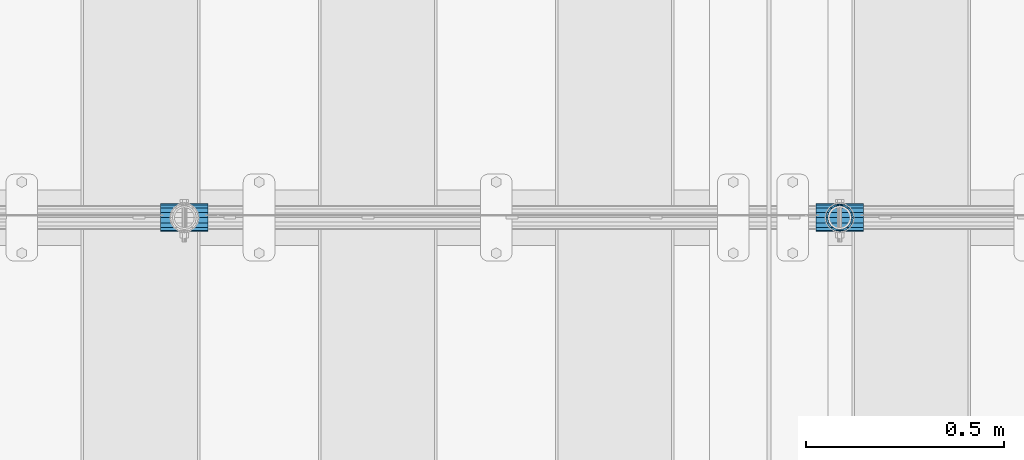
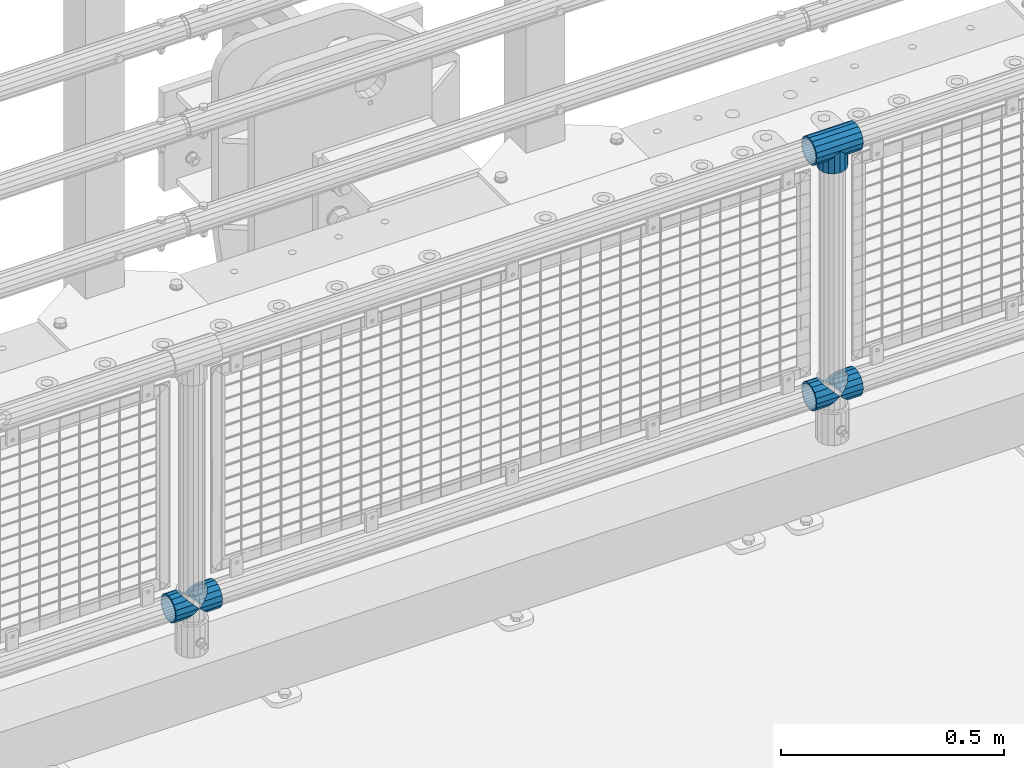
# One storey, part 142 of 219: 6 beams.
"""IFC2X3 building model written with IfcOpenShell, lengths in millimetres."""

import ifcopenshell
import ifcopenshell.guid

model = None  # the IFC model being written
_history = None  # IfcOwnerHistory: only IFC2X3 demands one
_inside = {}  # id of a spatial element -> (the spatial element, [elements in it])
_under = {}  # id of a project, library or spatial element -> (it, [spatial elements below it])
_declared = {}  # id of a project -> (the project, [libraries it declares])
_typed = {}  # id of a type object -> (the type object, [elements of that type])
_made_of = {}  # id of a material, layer set ... -> (it, [elements and type objects made of it])


def new_model(schema):
    """Start an empty IFC model of exactly this schema.

    Asked for "IFC4X3", IfcOpenShell would pick the latest addendum, in which some entities
    have other attributes; the version numbers below select the first issue.
    IFC2X3 requires an IfcOwnerHistory on every rooted entity: one is made here for all.
    """
    global model, _history
    if schema == "IFC4X3":
        model = ifcopenshell.file(schema_version=(4, 3, 0, 0))
    else:
        model = ifcopenshell.file(schema=schema)
    _inside.clear()
    _under.clear()
    _declared.clear()
    _typed.clear()
    _made_of.clear()
    _history = None
    if model.schema == "IFC2X3":
        org = make("IfcOrganization", Name="unknown")
        user = make(
            "IfcPersonAndOrganization",
            ThePerson=make("IfcPerson", FamilyName="unknown"),
            TheOrganization=org,
        )
        app = make(
            "IfcApplication",
            ApplicationDeveloper=org,
            Version="unknown",
            ApplicationFullName="unknown",
            ApplicationIdentifier="unknown",
        )
        _history = make(
            "IfcOwnerHistory",
            OwningUser=user,
            OwningApplication=app,
            ChangeAction="ADDED",
            CreationDate=0,
        )
    return model


def make(cls, **values):
    """One entity of the class cls with the attributes given. An attribute that is None is left unset."""
    return model.create_entity(
        cls, **{name: value for name, value in values.items() if value is not None}
    )


def rooted(cls, **values):
    """An entity with a GlobalId (a new one), such as an element, a storey or a relation."""
    return make(cls, GlobalId=ifcopenshell.guid.new(), OwnerHistory=_history, **values)


def si_unit(unit_type, name, prefix=None):
    """IfcSIUnit, for example si_unit("LENGTHUNIT", "METRE", prefix="MILLI")."""
    return make("IfcSIUnit", UnitType=unit_type, Prefix=prefix, Name=name)


def assignment(units):
    """IfcUnitAssignment: the units of a project."""
    return None if units is None else make("IfcUnitAssignment", Units=units)


def point(xyz):
    """IfcCartesianPoint."""
    return None if xyz is None else make("IfcCartesianPoint", Coordinates=xyz)


def direction(xyz):
    """IfcDirection."""
    return None if xyz is None else make("IfcDirection", DirectionRatios=xyz)


def frame(location, z_axis=None, x_axis=None):
    """IfcAxis2Placement3D, a coordinate frame: its origin and axes. An axis left out is left unset."""
    return make(
        "IfcAxis2Placement3D",
        Location=point(location),
        Axis=direction(z_axis),
        RefDirection=direction(x_axis),
    )


def origin_with_axes():
    """The frame at (0, 0, 0) with the z axis (0, 0, 1) and the x axis (1, 0, 0) written out."""
    return frame((0.0, 0.0, 0.0), z_axis=(0.0, 0.0, 1.0), x_axis=(1.0, 0.0, 0.0))


def place(relative_to, where):
    """IfcLocalPlacement: puts the frame where relative to a parent placement (None: the world)."""
    return make(
        "IfcLocalPlacement", PlacementRelTo=relative_to, RelativePlacement=where
    )


def context(
    kind, dimensions, precision=None, world=None, true_north=None, identifier=None
):
    """IfcGeometricRepresentationContext, for example the 3D "Model" context."""
    return make(
        "IfcGeometricRepresentationContext",
        ContextIdentifier=identifier,
        ContextType=kind,
        CoordinateSpaceDimension=dimensions,
        Precision=precision,
        WorldCoordinateSystem=world,
        TrueNorth=true_north,
    )


def subcontext(parent, identifier, kind, view, scale=None):
    """IfcGeometricRepresentationSubContext, for example "Body" below "Model"."""
    return make(
        "IfcGeometricRepresentationSubContext",
        ContextIdentifier=identifier,
        ContextType=kind,
        ParentContext=parent,
        TargetScale=scale,
        TargetView=view,
    )


def project(units=None, contexts=None):
    """IfcProject with its units and contexts."""
    return rooted(
        "IfcProject",
        Name="project",
        RepresentationContexts=contexts,
        UnitsInContext=assignment(units),
    )


def spatial(cls, under=None, at=None, **own):
    """A site, building, storey or space (cls), placed at a placement, below another one or the project."""
    s = rooted(cls, ObjectPlacement=at, **own)
    if under is not None:
        _under.setdefault(under.id(), (under, []))[1].append(s)
    return s


def faces_of(points, faces, orient=None, outer=None):
    """IfcFace entities. A face is a list of loops; a loop is a list of indices into points, from 0.

    orient and outer hold one flag for each loop. By default every Orientation is true, the
    first loop of a face is its IfcFaceOuterBound and the others are IfcFaceBound.
    """
    made = []
    for i, loops in enumerate(faces):
        bounds = []
        for j, loop in enumerate(loops):
            is_outer = j == 0 if outer is None else outer[i][j]
            bounds.append(
                make(
                    "IfcFaceOuterBound" if is_outer else "IfcFaceBound",
                    Bound=make("IfcPolyLoop", Polygon=[points[k] for k in loop]),
                    Orientation=True if orient is None else orient[i][j],
                )
            )
        made.append(make("IfcFace", Bounds=bounds))
    return made


def faceted_brep(points, faces, orient=None, outer=None, voids=None):
    """IfcFacetedBrep: a solid bounded by flat faces; with voids (closed shells), ...WithVoids."""
    shared = [point(p) for p in points]
    hull = make("IfcClosedShell", CfsFaces=faces_of(shared, faces, orient, outer))
    if voids is None:
        return make("IfcFacetedBrep", Outer=hull)
    return make(
        "IfcFacetedBrepWithVoids",
        Outer=hull,
        Voids=[
            make(cls, CfsFaces=faces_of(shared, fs, o, b)) for cls, fs, o, b in voids
        ],
    )


def shape(context_of_items, identifier, shape_type, items):
    """IfcShapeRepresentation: the items that make up one representation, for example the "Body"."""
    return make(
        "IfcShapeRepresentation",
        ContextOfItems=context_of_items,
        RepresentationIdentifier=identifier,
        RepresentationType=shape_type,
        Items=items,
    )


def material(Name=None, Category=None):
    """IfcMaterial."""
    return make("IfcMaterial", Name=Name, Category=Category)


def made_of(thing, what):
    """Note that an element or type object is made of a material, layer set ...; save() writes the relation."""
    if what is not None:
        _made_of.setdefault(what.id(), (what, []))[1].append(thing)
    return thing


def type_object(cls, material=None, **own):
    """A type object (cls), such as IfcWallType, which elements share."""
    return made_of(rooted(cls, **own), material)


def element(
    cls,
    number,
    at=None,
    inside=None,
    cuts=None,
    type_object=None,
    material=None,
    context=None,
    identifier="Body",
    shape_type=None,
    held_by="IfcProductDefinitionShape",
    body=None,
    shapes=None,
    **own,
):
    """One element of the class cls, such as IfcWall. Its Tag is "e" and its number.

    at: its placement. inside: the storey or other place that contains it. cuts: it is an
    opening in that element (IfcRelVoidsElement). A single representation is given by context,
    identifier, shape_type and body (its items); several are given by shapes. held_by: the class
    of the entity that holds the representations. save() writes the other relations.
    """
    e = rooted(cls, Tag="e%d" % number, ObjectPlacement=at, **own)
    if body is not None:
        shapes = [shape(context, identifier, shape_type, body)]
    if shapes is not None:
        e.Representation = make(held_by, Representations=shapes)
    if inside is not None:
        _inside.setdefault(inside.id(), (inside, []))[1].append(e)
    if cuts is not None:
        rooted(
            "IfcRelVoidsElement", RelatingBuildingElement=cuts, RelatedOpeningElement=e
        )
    if type_object is not None:
        _typed.setdefault(type_object.id(), (type_object, []))[1].append(e)
    return made_of(e, material)


def aggregate(whole, parts):
    """IfcRelAggregates: a whole, such as a stair, and the parts it consists of."""
    return rooted("IfcRelAggregates", RelatingObject=whole, RelatedObjects=parts)


def save(model, path):
    """Write the relations noted so far, then the file.

    IfcRelAggregates (storeys below a building ...), IfcRelContainedInSpatialStructure (elements
    in a storey), IfcRelDefinesByType, IfcRelAssociatesMaterial and IfcRelDeclares: one each for
    every whole, place, type object, material and project.
    """
    for whole, parts in _under.values():
        aggregate(whole, parts)
    for where, things in _inside.values():
        rooted(
            "IfcRelContainedInSpatialStructure",
            RelatedElements=things,
            RelatingStructure=where,
        )
    for kind, things in _typed.values():
        rooted("IfcRelDefinesByType", RelatedObjects=things, RelatingType=kind)
    for what, things in _made_of.values():
        rooted("IfcRelAssociatesMaterial", RelatedObjects=things, RelatingMaterial=what)
    for by, libraries in _declared.values():
        rooted("IfcRelDeclares", RelatingContext=by, RelatedDefinitions=libraries)
    model.write(path)


model = new_model("IFC2X3")

# Units and contexts
model_context = context("Model", 3, precision=1e-05, world=origin_with_axes())
body_context = subcontext(model_context, "Body", "Model", "MODEL_VIEW")
ifc_project = project(units=[si_unit("LENGTHUNIT", "METRE", prefix="MILLI"), si_unit("AREAUNIT", "SQUARE_METRE"), si_unit("VOLUMEUNIT", "CUBIC_METRE"), si_unit("MASSUNIT", "GRAM", prefix="KILO"), si_unit("TIMEUNIT", "SECOND"), si_unit("PLANEANGLEUNIT", "RADIAN"), si_unit("SOLIDANGLEUNIT", "STERADIAN"), si_unit("THERMODYNAMICTEMPERATUREUNIT", "DEGREE_CELSIUS"), si_unit("LUMINOUSINTENSITYUNIT", "LUMEN")], contexts=[model_context])

# Site, building, storey
site_placement = place(None, origin_with_axes())
site = spatial("IfcSite", under=ifc_project, at=site_placement, CompositionType="ELEMENT")
building_placement = place(site_placement, origin_with_axes())
building = spatial("IfcBuilding", under=site, at=building_placement, Name="Standard", CompositionType="ELEMENT")
storey_placement = place(building_placement, origin_with_axes())
storey = spatial("IfcBuildingStorey", under=building, at=storey_placement, Name="Undefined", CompositionType="ELEMENT", Elevation=0.0)

# Beams
ifc_material = material(Name="Misc_Undefined")
beam_type = type_object("IfcBeamType", PredefinedType="NOTDEFINED")
beam_1_placement = place(storey_placement, frame((10569.0, 31664.5, 969.849999999999), z_axis=(0.0, 1.0, 0.0), x_axis=(0.0, 0.0, -1.0)))
element("IfcBeam", 1, at=beam_1_placement, inside=storey, type_object=beam_type, material=ifc_material, context=body_context, shape_type="Brep", body=[
    faceted_brep([(0.0, 0.0, 35.1500000000015), (13.4513226476338, 13.4513226476329, 32.4743655677703), (13.4513226476338, -13.4513226476329, 32.4743655677703), (24.8548033587067, -16.3810424080013, -24.8548033587067), (24.8548033587067, -24.8548033587072, -24.8548033587067), (32.4743655677721, -32.4743655677717, -13.4513226476338), (32.4743655677721, -26.8123795176712, -13.4513226476338), (27.1226768591077, -21.4606908090117, -21.46069080901), (0.0, 0.0, -35.1500000000015), (13.4513226476338, -13.4513226476329, -32.4743655677703), (13.4513226476338, 13.4513226476329, -32.4743655677703), (20.0882031229739, -11.6144421722805, -28.0397438117179), (16.6306603983649, 0.0, -30.3499999999985), (20.0882031229739, 11.6144421722805, -28.0397438117179), (24.8548033587067, 16.3810424080013, -24.8548033587067), (24.8548033587067, 24.8548033587072, -24.8548033587067), (27.1226768591077, 21.4606908090117, -21.46069080901), (32.4743655677721, 26.8123795176755, -13.4513226476338), (32.4743655677721, 32.4743655677717, -13.4513226476338), (32.8397438117172, 28.0397438117175, -11.614442172282), (35.1499999999996, 30.35, 0.0), (35.1499999999996, 35.15, 0.0), (32.8397438117172, 28.0397438117175, 11.614442172282), (32.4743655677721, 26.8123795176755, 13.4513226476338), (32.4743655677721, 32.4743655677717, 13.4513226476338), (27.1226768591096, 21.4606908090117, 21.46069080901), (24.8548033587067, 16.3810424080078, 24.8548033587067), (24.8548033587067, 24.8548033587072, 24.8548033587067), (20.0882031229849, 11.6144421722805, 28.0397438117179), (16.6306603983739, 0.0, 30.3499999999985), (20.0882031229849, -11.6144421722805, 28.0397438117179), (24.8548033587067, -16.3810424080013, 24.8548033587067), (24.8548033587067, -24.8548033587072, 24.8548033587067), (27.1226768591096, -21.4606908090117, 21.46069080901), (32.4743655677721, -26.8123795176755, 13.4513226476338), (32.4743655677721, -32.4743655677717, 13.4513226476338), (32.8397438117172, -28.0397438117175, 11.614442172282), (35.1499999999996, -30.35, 0.0), (35.1499999999996, -35.15, 0.0), (32.8397438117172, -28.0397438117175, -11.614442172282), (60.1499999999996, -24.8548033587072, -24.8548033587067), (60.1499999999996, -32.4743655677717, -13.4513226476338), (60.1499999999996, -13.4513226476329, -32.4743655677703), (60.1499999999996, 0.0, -35.1500000000015), (60.1499999999996, 13.4513226476329, -32.4743655677703), (60.1499999999996, 24.8548033587072, -24.8548033587067), (60.1499999999996, 32.4743655677717, -13.4513226476338), (60.1499999999996, 35.15, 0.0), (60.1499999999996, 32.4743655677717, 13.4513226476338), (60.1499999999996, 24.8548033587072, 24.8548033587067), (60.1499999999996, 13.4513226476329, 32.4743655677703), (60.1499999999996, 0.0, 35.1500000000015), (60.1499999999996, -13.4513226476329, 32.4743655677703), (60.1499999999996, -24.8548033587072, 24.8548033587067), (60.1499999999996, -32.4743655677717, 13.4513226476338), (60.1499999999996, -35.15, 0.0), (60.1499999999996, -21.4606908090117, 21.46069080901), (60.1499999999996, -11.6144421722805, 28.0397438117179), (60.1499999999996, 0.0, 30.3499999999985), (60.1499999999996, 11.6144421722805, 28.0397438117179), (60.1499999999996, 21.4606908090117, 21.46069080901), (60.1499999999996, 28.0397438117175, 11.614442172282), (60.1499999999996, 30.35, 0.0), (60.1499999999996, 28.0397438117175, -11.614442172282), (60.1499999999996, 21.4606908090117, -21.46069080901), (60.1499999999996, 11.6144421722805, -28.0397438117179), (60.1499999999996, 0.0, -30.3499999999985), (60.1499999999996, -11.6144421722805, -28.0397438117179), (60.1499999999996, -21.4606908090117, -21.46069080901), (60.1499999999996, -28.0397438117175, -11.614442172282), (60.1499999999996, -30.35, 0.0), (60.1499999999996, -28.0397438117175, 11.614442172282)], [[[0, 1, 2]], [[3, 4, 5, 6, 7]], [[8, 9, 10]], [[10, 9, 4, 3, 11, 12, 13, 14, 15]], [[15, 14, 16, 17, 18]], [[18, 17, 19, 20, 21]], [[21, 20, 22, 23, 24]], [[24, 23, 25, 26, 27]], [[27, 26, 28, 29, 30, 31, 32, 2, 1]], [[33, 34, 35, 32, 31]], [[36, 37, 38, 35, 34]], [[6, 5, 38, 37, 39]], [[40, 41, 5, 4]], [[42, 40, 4, 9]], [[43, 42, 9, 8]], [[44, 43, 8, 10]], [[45, 44, 10, 15]], [[46, 45, 15, 18]], [[47, 46, 18, 21]], [[48, 47, 21, 24]], [[49, 48, 24, 27]], [[50, 49, 27, 1]], [[51, 50, 1, 0]], [[52, 51, 0, 2]], [[53, 52, 2, 32]], [[54, 53, 32, 35]], [[55, 54, 35, 38]], [[41, 55, 38, 5]], [[40, 42, 43, 44, 45, 46, 47, 48, 49, 50, 51, 52, 53, 54, 55, 41], [56, 57, 58, 59, 60, 61, 62, 63, 64, 65, 66, 67, 68, 69, 70, 71]], [[71, 70, 37, 36]], [[56, 71, 36, 34, 33]], [[57, 56, 33, 31, 30]], [[58, 57, 30, 29]], [[59, 58, 29, 28]], [[25, 60, 59, 28, 26]], [[22, 61, 60, 25, 23]], [[62, 61, 22, 20]], [[63, 62, 20, 19]], [[64, 63, 19, 17, 16]], [[65, 64, 16, 14, 13]], [[66, 65, 13, 12]], [[67, 66, 12, 11]], [[7, 68, 67, 11, 3]], [[39, 69, 68, 7, 6]], [[70, 69, 39, 37]]]),
])
beam_2_placement = place(storey_placement, frame((10508.85, 31664.5, 969.849999999999), z_axis=(0.0, 0.0, 1.0), x_axis=(1.0, 0.0, 0.0)))
element("IfcBeam", 2, at=beam_2_placement, inside=storey, type_object=beam_type, material=ifc_material, context=body_context, shape_type="Brep", body=[
    faceted_brep([(88.1897438117176, -11.614442172282, -28.0397438117176), (88.1897438117176, -11.614442172282, -32.8397438117162), (86.9623795176776, -13.4513226476338, -32.4743655677718), (81.6106908090114, -21.46069080901, -27.1226768591079), (81.6106908090114, -21.46069080901, -21.4606908090117), (76.5310424080035, -24.8548033587067, -24.8548033587072), (71.7644421722798, -28.0397438117179, -20.0882031229796), (71.7644421722798, -28.0397438117179, -11.6144421722805), (60.1499999999996, -30.3499999999985, -16.6306603983671), (60.1499999999996, -30.35, 0.0), (48.5355578277195, -28.0397438117179, -20.0882031229796), (48.5355578277195, -28.0397438117179, -11.6144421722805), (43.7689575919958, -24.8548033587067, -24.8548033587072), (38.6893091909878, -21.46069080901, -27.1226768591079), (38.6893091909878, -21.46069080901, -21.4606908090117), (33.3376204823271, -13.4513226476338, -32.4743655677718), (32.1102561882817, -11.614442172282, -32.8397438117162), (32.1102561882817, -11.614442172282, -28.0397438117176), (29.7999999999993, 0.0, -35.15), (29.7999999999993, 0.0, -30.35), (32.1102561882817, 11.614442172282, -32.8397438117171), (32.1102561882817, 11.614442172282, -28.0397438117176), (33.3376204823217, 13.4513226476338, -32.4743655677718), (38.6893091909878, 21.46069080901, -27.1226768591122), (38.6893091909878, 21.46069080901, -21.4606908090117), (43.7689575919958, 24.8548033587067, -24.8548033587072), (48.5355578277195, 28.0397438117179, -20.0882031229861), (48.5355578277195, 28.0397438117179, -11.6144421722805), (60.1499999999996, 30.3499999999985, -16.6306603983737), (60.1499999999996, 30.35, 0.0), (71.7644421722798, 28.0397438117179, -20.0882031229861), (71.7644421722798, 28.0397438117179, -11.6144421722805), (76.5310424080035, 24.8548033587067, -24.8548033587072), (81.6106908090114, 21.46069080901, -27.1226768591122), (81.6106908090114, 21.46069080901, -21.4606908090117), (86.9623795176722, 13.4513226476338, -32.4743655677718), (88.1897438117176, 11.614442172282, -32.8397438117171), (88.1897438117176, 11.614442172282, -28.0397438117176), (90.5, 0.0, -35.15), (90.5, 0.0, -30.35), (0.0, -21.46069080901, -21.4606908090118), (0.0, -28.0397438117179, -11.6144421722802), (0.0, -11.614442172282, -28.0397438117179), (0.0, 0.0, -30.3500000000004), (0.0, 11.614442172282, -28.0397438117179), (0.0, 21.46069080901, -21.4606908090118), (0.0, 28.0397438117179, -11.6144421722802), (0.0, 30.3499999999985, 0.0), (0.0, 32.4743655677703, -13.4513226476338), (0.0, 35.1500000000015, 0.0), (120.299999999999, 35.1500000000015, 0.0), (120.299999999999, 32.4743655677703, -13.4513226476329), (0.0, 32.4743655677703, 13.4513226476338), (120.299999999999, 32.4743655677703, 13.4513226476329), (0.0, 24.8548033587067, 24.8548033587067), (120.299999999999, 24.8548033587067, 24.8548033587072), (0.0, 13.4513226476338, 32.4743655677721), (120.299999999999, 13.4513226476338, 32.4743655677718), (0.0, 0.0, 35.1500000000015), (120.299999999999, 0.0, 35.15), (0.0, -13.4513226476338, 32.4743655677721), (120.299999999999, -13.4513226476338, 32.4743655677718), (0.0, -24.8548033587067, 24.8548033587067), (120.299999999999, -24.8548033587067, 24.8548033587072), (0.0, -32.4743655677703, 13.4513226476338), (120.299999999999, -32.4743655677703, 13.4513226476329), (0.0, -35.1500000000015, 0.0), (120.299999999999, -35.1500000000015, 0.0), (0.0, -32.4743655677703, -13.4513226476338), (120.299999999999, -32.4743655677703, -13.4513226476329), (0.0, 24.8548033587067, -24.8548033587067), (0.0, 13.4513226476338, -32.4743655677721), (0.0, 0.0, -35.1500000000015), (0.0, -13.4513226476338, -32.4743655677721), (0.0, -24.8548033587067, -24.8548033587067), (0.0, 28.0397438117179, 11.6144421722802), (0.0, 21.46069080901, 21.4606908090118), (0.0, 11.614442172282, 28.0397438117179), (0.0, 0.0, 30.3500000000004), (0.0, -11.614442172282, 28.0397438117179), (0.0, -21.46069080901, 21.4606908090118), (0.0, -28.0397438117179, 11.6144421722802), (0.0, -30.3499999999985, 0.0), (120.299999999999, -30.3499999999985, 0.0), (120.299999999999, -28.0397438117179, -11.6144421722805), (120.299999999999, -21.46069080901, -21.4606908090117), (120.299999999999, -11.614442172282, -28.0397438117176), (120.299999999999, 0.0, -30.35), (120.299999999999, 21.46069080901, -21.4606908090117), (120.299999999999, 28.0397438117179, -11.6144421722805), (120.299999999999, 11.614442172282, -28.0397438117176), (120.299999999999, 30.3499999999985, 0.0), (120.299999999999, 28.0397438117179, 11.6144421722805), (120.299999999999, 21.46069080901, 21.4606908090117), (120.299999999999, 11.614442172282, 28.0397438117176), (120.299999999999, 0.0, 30.35), (120.299999999999, -11.614442172282, 28.0397438117176), (120.299999999999, -21.46069080901, 21.4606908090117), (120.299999999999, -28.0397438117179, 11.6144421722805), (120.299999999999, -24.8548033587067, -24.8548033587072), (120.299999999999, -13.4513226476338, -32.4743655677718), (120.299999999999, 0.0, -35.15), (120.299999999999, 13.4513226476338, -32.4743655677718), (120.299999999999, 24.8548033587067, -24.8548033587072)], [[[0, 1, 2, 3, 4]], [[4, 3, 5, 6, 7]], [[7, 6, 8, 9]], [[9, 8, 10, 11]], [[11, 10, 12, 13, 14]], [[14, 13, 15, 16, 17]], [[17, 16, 18, 19]], [[19, 18, 20, 21]], [[21, 20, 22, 23, 24]], [[24, 23, 25, 26, 27]], [[27, 26, 28, 29]], [[29, 28, 30, 31]], [[31, 30, 32, 33, 34]], [[34, 33, 35, 36, 37]], [[37, 36, 38, 39]], [[39, 38, 1, 0]], [[40, 41, 11, 14]], [[42, 40, 14, 17]], [[43, 42, 17, 19]], [[44, 43, 19, 21]], [[45, 44, 21, 24]], [[46, 45, 24, 27]], [[47, 46, 27, 29]], [[48, 49, 50, 51]], [[49, 52, 53, 50]], [[52, 54, 55, 53]], [[54, 56, 57, 55]], [[56, 58, 59, 57]], [[58, 60, 61, 59]], [[60, 62, 63, 61]], [[62, 64, 65, 63]], [[64, 66, 67, 65]], [[66, 68, 69, 67]], [[64, 62, 60, 58, 56, 54, 52, 49, 48, 70, 71, 72, 73, 74, 68, 66], [41, 40, 42, 43, 44, 45, 46, 47, 75, 76, 77, 78, 79, 80, 81, 82]], [[41, 82, 9, 11]], [[83, 84, 7, 9]], [[84, 85, 4, 7]], [[85, 86, 0, 4]], [[86, 87, 39, 0]], [[88, 89, 31, 34]], [[90, 88, 34, 37]], [[87, 90, 37, 39]], [[89, 91, 29, 31]], [[75, 47, 29, 91, 92]], [[76, 75, 92, 93]], [[77, 76, 93, 94]], [[78, 77, 94, 95]], [[79, 78, 95, 96]], [[80, 79, 96, 97]], [[81, 80, 97, 98]], [[9, 82, 81, 98, 83]], [[99, 100, 101, 102, 103, 51, 50, 53, 55, 57, 59, 61, 63, 65, 67, 69], [97, 96, 95, 94, 93, 92, 91, 89, 88, 90, 87, 86, 85, 84, 83, 98]], [[35, 102, 101, 38, 36]], [[32, 103, 102, 35, 33]], [[28, 26, 25, 70, 48, 51, 103, 32, 30]], [[22, 71, 70, 25, 23]], [[18, 72, 71, 22, 20]], [[73, 72, 18, 16, 15]], [[74, 73, 15, 13, 12]], [[99, 69, 68, 74, 12, 10, 8, 6, 5]], [[100, 99, 5, 3, 2]], [[101, 100, 2, 1, 38]]]),
])
beam_3_placement = place(storey_placement, frame((8850.85, 31664.5, 298.17), z_axis=(0.0, 1.0, 0.0), x_axis=(1.0, 0.0, 0.0)))
element("IfcBeam", 3, at=beam_3_placement, inside=storey, type_object=beam_type, material=ifc_material, context=body_context, shape_type="Brep", body=[
    faceted_brep([(60.1499999999996, 0.0, -35.1500000000015), (46.6986773523668, 13.4513226476329, -32.4743655677703), (46.6986773523668, -13.4513226476329, -32.4743655677703), (33.0273231408928, 21.4606908090117, 21.46069080901), (27.675634432228, 26.8123795176712, 13.4513226476338), (27.675634432228, 32.4743655677717, 13.4513226476338), (35.2951966412925, 24.8548033587072, 24.8548033587067), (35.2951966412925, 16.3810424080078, 24.8548033587067), (27.3102561882824, 28.0397438117175, 11.614442172282), (24.9999999999995, 30.35, 0.0), (24.9999999999995, 35.15, 0.0), (27.675634432228, 26.8123795176755, -13.4513226476338), (27.675634432228, 32.4743655677717, -13.4513226476338), (27.3102561882829, 28.0397438117175, -11.614442172282), (35.2951966412925, 16.3810424080013, -24.8548033587067), (35.2951966412925, 24.8548033587072, -24.8548033587067), (33.0273231408896, 21.4606908090117, -21.46069080901), (40.0617968770143, 11.6144421722805, -28.0397438117179), (43.5193396016266, 0.0, -30.3499999999985), (40.0617968770143, -11.6144421722805, -28.0397438117179), (35.2951966412925, -16.3810424080013, -24.8548033587067), (35.2951966412925, -24.8548033587072, -24.8548033587067), (33.0273231408896, -21.4606908090117, -21.46069080901), (27.675634432228, -26.8123795176755, -13.4513226476338), (27.675634432228, -32.4743655677717, -13.4513226476338), (27.3102561882829, -28.0397438117175, -11.614442172282), (24.9999999999995, -30.35, 0.0), (24.9999999999995, -35.15, 0.0), (27.3102561882824, -28.0397438117175, 11.614442172282), (27.675634432228, -26.8123795176755, 13.4513226476338), (27.675634432228, -32.4743655677717, 13.4513226476338), (33.0273231408928, -21.4606908090117, 21.46069080901), (35.2951966412925, -16.3810424080013, 24.8548033587067), (35.2951966412925, -24.8548033587072, 24.8548033587067), (60.1499999999996, 0.0, 35.1500000000015), (46.6986773523668, -13.4513226476329, 32.4743655677703), (46.6986773523668, 13.4513226476329, 32.4743655677703), (40.0617968770207, -11.6144421722805, 28.0397438117179), (43.519339601633, 0.0, 30.3499999999985), (40.0617968770207, 11.6144421722805, 28.0397438117179), (0.0, -32.4743655677703, -13.4513226476338), (0.0, -24.8548033587067, -24.8548033587067), (0.0, -13.4513226476338, -32.4743655677721), (0.0, 0.0, -35.1500000000015), (0.0, 13.4513226476338, -32.4743655677721), (0.0, 24.8548033587067, -24.8548033587067), (0.0, 32.4743655677703, -13.4513226476338), (0.0, 35.1500000000015, 0.0), (0.0, 32.4743655677703, 13.4513226476338), (0.0, 24.8548033587067, 24.8548033587067), (0.0, 13.4513226476338, 32.4743655677721), (0.0, 0.0, 35.1500000000015), (0.0, -32.4743655677703, 13.4513226476338), (0.0, -35.1500000000015, 0.0), (0.0, -24.8548033587067, 24.8548033587067), (0.0, -13.4513226476338, 32.4743655677721), (0.0, -28.0397438117179, -11.6144421722802), (0.0, -21.46069080901, -21.4606908090118), (0.0, -11.614442172282, -28.0397438117179), (0.0, 0.0, -30.3500000000004), (0.0, 11.614442172282, -28.0397438117179), (0.0, 21.46069080901, -21.4606908090118), (0.0, 28.0397438117179, -11.6144421722802), (0.0, 30.3499999999985, 0.0), (0.0, 28.0397438117179, 11.6144421722802), (0.0, 21.46069080901, 21.4606908090118), (0.0, 11.614442172282, 28.0397438117179), (0.0, 0.0, 30.3500000000004), (0.0, -11.614442172282, 28.0397438117179), (0.0, -21.46069080901, 21.4606908090118), (0.0, -28.0397438117179, 11.6144421722802), (0.0, -30.3499999999985, 0.0)], [[[0, 1, 2]], [[3, 4, 5, 6, 7]], [[8, 9, 10, 5, 4]], [[11, 12, 10, 9, 13]], [[14, 15, 12, 11, 16]], [[2, 1, 15, 14, 17, 18, 19, 20, 21]], [[21, 20, 22, 23, 24]], [[24, 23, 25, 26, 27]], [[27, 26, 28, 29, 30]], [[30, 29, 31, 32, 33]], [[34, 35, 36]], [[33, 32, 37, 38, 39, 7, 6, 36, 35]], [[40, 41, 21, 24]], [[41, 42, 2, 21]], [[42, 43, 0, 2]], [[43, 44, 1, 0]], [[44, 45, 15, 1]], [[45, 46, 12, 15]], [[46, 47, 10, 12]], [[47, 48, 5, 10]], [[48, 49, 6, 5]], [[49, 50, 36, 6]], [[50, 51, 34, 36]], [[52, 53, 27, 30]], [[54, 52, 30, 33]], [[55, 54, 33, 35]], [[51, 55, 35, 34]], [[53, 40, 24, 27]], [[52, 54, 55, 51, 50, 49, 48, 47, 46, 45, 44, 43, 42, 41, 40, 53], [56, 57, 58, 59, 60, 61, 62, 63, 64, 65, 66, 67, 68, 69, 70, 71]], [[68, 67, 38, 37]], [[31, 69, 68, 37, 32]], [[28, 70, 69, 31, 29]], [[71, 70, 28, 26]], [[56, 71, 26, 25]], [[57, 56, 25, 23, 22]], [[58, 57, 22, 20, 19]], [[59, 58, 19, 18]], [[60, 59, 18, 17]], [[16, 61, 60, 17, 14]], [[13, 62, 61, 16, 11]], [[63, 62, 13, 9]], [[64, 63, 9, 8]], [[65, 64, 8, 4, 3]], [[66, 65, 3, 7, 39]], [[67, 66, 39, 38]]]),
])
beam_4_placement = place(storey_placement, frame((8911.0, 31664.5, 298.17), z_axis=(0.0, 1.0, 0.0), x_axis=(1.0, 0.0, 0.0)))
element("IfcBeam", 4, at=beam_4_placement, inside=storey, type_object=beam_type, material=ifc_material, context=body_context, shape_type="Brep", body=[
    faceted_brep([(0.0, 0.0, 35.1500000000015), (13.4513226476338, 13.4513226476329, 32.4743655677703), (13.4513226476338, -13.4513226476329, 32.4743655677703), (24.8548033587067, -16.3810424080013, -24.8548033587067), (24.8548033587067, -24.8548033587072, -24.8548033587067), (32.4743655677721, -32.4743655677717, -13.4513226476338), (32.4743655677721, -26.8123795176712, -13.4513226476338), (27.1226768591077, -21.4606908090117, -21.46069080901), (0.0, 0.0, -35.1500000000015), (13.4513226476338, -13.4513226476329, -32.4743655677703), (13.4513226476338, 13.4513226476329, -32.4743655677703), (20.0882031229739, -11.6144421722805, -28.0397438117179), (16.6306603983649, 0.0, -30.3499999999985), (20.0882031229739, 11.6144421722805, -28.0397438117179), (24.8548033587067, 16.3810424080013, -24.8548033587067), (24.8548033587067, 24.8548033587072, -24.8548033587067), (27.1226768591077, 21.4606908090117, -21.46069080901), (32.4743655677721, 26.8123795176755, -13.4513226476338), (32.4743655677721, 32.4743655677717, -13.4513226476338), (32.8397438117172, 28.0397438117175, -11.614442172282), (35.1499999999996, 30.35, 0.0), (35.1499999999996, 35.15, 0.0), (32.8397438117172, 28.0397438117175, 11.614442172282), (32.4743655677721, 26.8123795176755, 13.4513226476338), (32.4743655677721, 32.4743655677717, 13.4513226476338), (27.1226768591096, 21.4606908090117, 21.46069080901), (24.8548033587067, 16.3810424080078, 24.8548033587067), (24.8548033587067, 24.8548033587072, 24.8548033587067), (20.0882031229849, 11.6144421722805, 28.0397438117179), (16.6306603983739, 0.0, 30.3499999999985), (20.0882031229849, -11.6144421722805, 28.0397438117179), (24.8548033587067, -16.3810424080013, 24.8548033587067), (24.8548033587067, -24.8548033587072, 24.8548033587067), (27.1226768591096, -21.4606908090117, 21.46069080901), (32.4743655677721, -26.8123795176755, 13.4513226476338), (32.4743655677721, -32.4743655677717, 13.4513226476338), (32.8397438117172, -28.0397438117175, 11.614442172282), (35.1499999999996, -30.35, 0.0), (35.1499999999996, -35.15, 0.0), (32.8397438117172, -28.0397438117175, -11.614442172282), (60.1499999999996, -24.8548033587072, -24.8548033587067), (60.1499999999996, -32.4743655677717, -13.4513226476338), (60.1499999999996, -13.4513226476329, -32.4743655677703), (60.1499999999996, 0.0, -35.1500000000015), (60.1499999999996, 13.4513226476329, -32.4743655677703), (60.1499999999996, 24.8548033587072, -24.8548033587067), (60.1499999999996, 32.4743655677717, -13.4513226476338), (60.1499999999996, 35.15, 0.0), (60.1499999999996, 32.4743655677717, 13.4513226476338), (60.1499999999996, 24.8548033587072, 24.8548033587067), (60.1499999999996, 13.4513226476329, 32.4743655677703), (60.1499999999996, 0.0, 35.1500000000015), (60.1499999999996, -13.4513226476329, 32.4743655677703), (60.1499999999996, -24.8548033587072, 24.8548033587067), (60.1499999999996, -32.4743655677717, 13.4513226476338), (60.1499999999996, -35.15, 0.0), (60.1499999999996, -21.4606908090117, 21.46069080901), (60.1499999999996, -11.6144421722805, 28.0397438117179), (60.1499999999996, 0.0, 30.3499999999985), (60.1499999999996, 11.6144421722805, 28.0397438117179), (60.1499999999996, 21.4606908090117, 21.46069080901), (60.1499999999996, 28.0397438117175, 11.614442172282), (60.1499999999996, 30.35, 0.0), (60.1499999999996, 28.0397438117175, -11.614442172282), (60.1499999999996, 21.4606908090117, -21.46069080901), (60.1499999999996, 11.6144421722805, -28.0397438117179), (60.1499999999996, 0.0, -30.3499999999985), (60.1499999999996, -11.6144421722805, -28.0397438117179), (60.1499999999996, -21.4606908090117, -21.46069080901), (60.1499999999996, -28.0397438117175, -11.614442172282), (60.1499999999996, -30.35, 0.0), (60.1499999999996, -28.0397438117175, 11.614442172282)], [[[0, 1, 2]], [[3, 4, 5, 6, 7]], [[8, 9, 10]], [[10, 9, 4, 3, 11, 12, 13, 14, 15]], [[15, 14, 16, 17, 18]], [[18, 17, 19, 20, 21]], [[21, 20, 22, 23, 24]], [[24, 23, 25, 26, 27]], [[27, 26, 28, 29, 30, 31, 32, 2, 1]], [[33, 34, 35, 32, 31]], [[36, 37, 38, 35, 34]], [[6, 5, 38, 37, 39]], [[40, 41, 5, 4]], [[42, 40, 4, 9]], [[43, 42, 9, 8]], [[44, 43, 8, 10]], [[45, 44, 10, 15]], [[46, 45, 15, 18]], [[47, 46, 18, 21]], [[48, 47, 21, 24]], [[49, 48, 24, 27]], [[50, 49, 27, 1]], [[51, 50, 1, 0]], [[52, 51, 0, 2]], [[53, 52, 2, 32]], [[54, 53, 32, 35]], [[55, 54, 35, 38]], [[41, 55, 38, 5]], [[40, 42, 43, 44, 45, 46, 47, 48, 49, 50, 51, 52, 53, 54, 55, 41], [56, 57, 58, 59, 60, 61, 62, 63, 64, 65, 66, 67, 68, 69, 70, 71]], [[71, 70, 37, 36]], [[56, 71, 36, 34, 33]], [[57, 56, 33, 31, 30]], [[58, 57, 30, 29]], [[59, 58, 29, 28]], [[25, 60, 59, 28, 26]], [[22, 61, 60, 25, 23]], [[62, 61, 22, 20]], [[63, 62, 20, 19]], [[64, 63, 19, 17, 16]], [[65, 64, 16, 14, 13]], [[66, 65, 13, 12]], [[67, 66, 12, 11]], [[7, 68, 67, 11, 3]], [[39, 69, 68, 7, 6]], [[70, 69, 39, 37]]]),
])
beam_5_placement = place(storey_placement, frame((10508.85, 31664.5, 298.17), z_axis=(0.0, 1.0, 0.0), x_axis=(1.0, 0.0, 0.0)))
element("IfcBeam", 5, at=beam_5_placement, inside=storey, type_object=beam_type, material=ifc_material, context=body_context, shape_type="Brep", body=[
    faceted_brep([(60.1499999999996, 0.0, -35.1500000000015), (46.6986773523668, 13.4513226476329, -32.4743655677703), (46.6986773523668, -13.4513226476329, -32.4743655677703), (33.0273231408928, 21.4606908090117, 21.46069080901), (27.675634432228, 26.8123795176712, 13.4513226476338), (27.675634432228, 32.4743655677717, 13.4513226476338), (35.2951966412925, 24.8548033587072, 24.8548033587067), (35.2951966412925, 16.3810424080078, 24.8548033587067), (27.3102561882824, 28.0397438117175, 11.614442172282), (24.9999999999995, 30.35, 0.0), (24.9999999999995, 35.15, 0.0), (27.675634432228, 26.8123795176755, -13.4513226476338), (27.675634432228, 32.4743655677717, -13.4513226476338), (27.3102561882829, 28.0397438117175, -11.614442172282), (35.2951966412925, 16.3810424080013, -24.8548033587067), (35.2951966412925, 24.8548033587072, -24.8548033587067), (33.0273231408896, 21.4606908090117, -21.46069080901), (40.0617968770143, 11.6144421722805, -28.0397438117179), (43.5193396016266, 0.0, -30.3499999999985), (40.0617968770143, -11.6144421722805, -28.0397438117179), (35.2951966412925, -16.3810424080013, -24.8548033587067), (35.2951966412925, -24.8548033587072, -24.8548033587067), (33.0273231408896, -21.4606908090117, -21.46069080901), (27.675634432228, -26.8123795176755, -13.4513226476338), (27.675634432228, -32.4743655677717, -13.4513226476338), (27.3102561882829, -28.0397438117175, -11.614442172282), (24.9999999999995, -30.35, 0.0), (24.9999999999995, -35.15, 0.0), (27.3102561882824, -28.0397438117175, 11.614442172282), (27.675634432228, -26.8123795176755, 13.4513226476338), (27.675634432228, -32.4743655677717, 13.4513226476338), (33.0273231408928, -21.4606908090117, 21.46069080901), (35.2951966412925, -16.3810424080013, 24.8548033587067), (35.2951966412925, -24.8548033587072, 24.8548033587067), (60.1499999999996, 0.0, 35.1500000000015), (46.6986773523668, -13.4513226476329, 32.4743655677703), (46.6986773523668, 13.4513226476329, 32.4743655677703), (40.0617968770207, -11.6144421722805, 28.0397438117179), (43.519339601633, 0.0, 30.3499999999985), (40.0617968770207, 11.6144421722805, 28.0397438117179), (0.0, -32.4743655677703, -13.4513226476338), (0.0, -24.8548033587067, -24.8548033587067), (0.0, -13.4513226476338, -32.4743655677721), (0.0, 0.0, -35.1500000000015), (0.0, 13.4513226476338, -32.4743655677721), (0.0, 24.8548033587067, -24.8548033587067), (0.0, 32.4743655677703, -13.4513226476338), (0.0, 35.1500000000015, 0.0), (0.0, 32.4743655677703, 13.4513226476338), (0.0, 24.8548033587067, 24.8548033587067), (0.0, 13.4513226476338, 32.4743655677721), (0.0, 0.0, 35.1500000000015), (0.0, -32.4743655677703, 13.4513226476338), (0.0, -35.1500000000015, 0.0), (0.0, -24.8548033587067, 24.8548033587067), (0.0, -13.4513226476338, 32.4743655677721), (0.0, -28.0397438117179, -11.6144421722802), (0.0, -21.46069080901, -21.4606908090118), (0.0, -11.614442172282, -28.0397438117179), (0.0, 0.0, -30.3500000000004), (0.0, 11.614442172282, -28.0397438117179), (0.0, 21.46069080901, -21.4606908090118), (0.0, 28.0397438117179, -11.6144421722802), (0.0, 30.3499999999985, 0.0), (0.0, 28.0397438117179, 11.6144421722802), (0.0, 21.46069080901, 21.4606908090118), (0.0, 11.614442172282, 28.0397438117179), (0.0, 0.0, 30.3500000000004), (0.0, -11.614442172282, 28.0397438117179), (0.0, -21.46069080901, 21.4606908090118), (0.0, -28.0397438117179, 11.6144421722802), (0.0, -30.3499999999985, 0.0)], [[[0, 1, 2]], [[3, 4, 5, 6, 7]], [[8, 9, 10, 5, 4]], [[11, 12, 10, 9, 13]], [[14, 15, 12, 11, 16]], [[2, 1, 15, 14, 17, 18, 19, 20, 21]], [[21, 20, 22, 23, 24]], [[24, 23, 25, 26, 27]], [[27, 26, 28, 29, 30]], [[30, 29, 31, 32, 33]], [[34, 35, 36]], [[33, 32, 37, 38, 39, 7, 6, 36, 35]], [[40, 41, 21, 24]], [[41, 42, 2, 21]], [[42, 43, 0, 2]], [[43, 44, 1, 0]], [[44, 45, 15, 1]], [[45, 46, 12, 15]], [[46, 47, 10, 12]], [[47, 48, 5, 10]], [[48, 49, 6, 5]], [[49, 50, 36, 6]], [[50, 51, 34, 36]], [[52, 53, 27, 30]], [[54, 52, 30, 33]], [[55, 54, 33, 35]], [[51, 55, 35, 34]], [[53, 40, 24, 27]], [[52, 54, 55, 51, 50, 49, 48, 47, 46, 45, 44, 43, 42, 41, 40, 53], [56, 57, 58, 59, 60, 61, 62, 63, 64, 65, 66, 67, 68, 69, 70, 71]], [[68, 67, 38, 37]], [[31, 69, 68, 37, 32]], [[28, 70, 69, 31, 29]], [[71, 70, 28, 26]], [[56, 71, 26, 25]], [[57, 56, 25, 23, 22]], [[58, 57, 22, 20, 19]], [[59, 58, 19, 18]], [[60, 59, 18, 17]], [[16, 61, 60, 17, 14]], [[13, 62, 61, 16, 11]], [[63, 62, 13, 9]], [[64, 63, 9, 8]], [[65, 64, 8, 4, 3]], [[66, 65, 3, 7, 39]], [[67, 66, 39, 38]]]),
])
beam_6_placement = place(storey_placement, frame((10569.0, 31664.5, 298.17), z_axis=(0.0, 1.0, 0.0), x_axis=(1.0, 0.0, 0.0)))
element("IfcBeam", 6, at=beam_6_placement, inside=storey, type_object=beam_type, material=ifc_material, context=body_context, shape_type="Brep", body=[
    faceted_brep([(0.0, 0.0, 35.1500000000015), (13.4513226476338, 13.4513226476329, 32.4743655677703), (13.4513226476338, -13.4513226476329, 32.4743655677703), (24.8548033587067, -16.3810424080013, -24.8548033587067), (24.8548033587067, -24.8548033587072, -24.8548033587067), (32.4743655677721, -32.4743655677717, -13.4513226476338), (32.4743655677721, -26.8123795176712, -13.4513226476338), (27.1226768591077, -21.4606908090117, -21.46069080901), (0.0, 0.0, -35.1500000000015), (13.4513226476338, -13.4513226476329, -32.4743655677703), (13.4513226476338, 13.4513226476329, -32.4743655677703), (20.0882031229739, -11.6144421722805, -28.0397438117179), (16.6306603983649, 0.0, -30.3499999999985), (20.0882031229739, 11.6144421722805, -28.0397438117179), (24.8548033587067, 16.3810424080013, -24.8548033587067), (24.8548033587067, 24.8548033587072, -24.8548033587067), (27.1226768591077, 21.4606908090117, -21.46069080901), (32.4743655677721, 26.8123795176755, -13.4513226476338), (32.4743655677721, 32.4743655677717, -13.4513226476338), (32.8397438117172, 28.0397438117175, -11.614442172282), (35.1499999999996, 30.35, 0.0), (35.1499999999996, 35.15, 0.0), (32.8397438117172, 28.0397438117175, 11.614442172282), (32.4743655677721, 26.8123795176755, 13.4513226476338), (32.4743655677721, 32.4743655677717, 13.4513226476338), (27.1226768591096, 21.4606908090117, 21.46069080901), (24.8548033587067, 16.3810424080078, 24.8548033587067), (24.8548033587067, 24.8548033587072, 24.8548033587067), (20.0882031229849, 11.6144421722805, 28.0397438117179), (16.6306603983739, 0.0, 30.3499999999985), (20.0882031229849, -11.6144421722805, 28.0397438117179), (24.8548033587067, -16.3810424080013, 24.8548033587067), (24.8548033587067, -24.8548033587072, 24.8548033587067), (27.1226768591096, -21.4606908090117, 21.46069080901), (32.4743655677721, -26.8123795176755, 13.4513226476338), (32.4743655677721, -32.4743655677717, 13.4513226476338), (32.8397438117172, -28.0397438117175, 11.614442172282), (35.1499999999996, -30.35, 0.0), (35.1499999999996, -35.15, 0.0), (32.8397438117172, -28.0397438117175, -11.614442172282), (60.1499999999996, -24.8548033587072, -24.8548033587067), (60.1499999999996, -32.4743655677717, -13.4513226476338), (60.1499999999996, -13.4513226476329, -32.4743655677703), (60.1499999999996, 0.0, -35.1500000000015), (60.1499999999996, 13.4513226476329, -32.4743655677703), (60.1499999999996, 24.8548033587072, -24.8548033587067), (60.1499999999996, 32.4743655677717, -13.4513226476338), (60.1499999999996, 35.15, 0.0), (60.1499999999996, 32.4743655677717, 13.4513226476338), (60.1499999999996, 24.8548033587072, 24.8548033587067), (60.1499999999996, 13.4513226476329, 32.4743655677703), (60.1499999999996, 0.0, 35.1500000000015), (60.1499999999996, -13.4513226476329, 32.4743655677703), (60.1499999999996, -24.8548033587072, 24.8548033587067), (60.1499999999996, -32.4743655677717, 13.4513226476338), (60.1499999999996, -35.15, 0.0), (60.1499999999996, -21.4606908090117, 21.46069080901), (60.1499999999996, -11.6144421722805, 28.0397438117179), (60.1499999999996, 0.0, 30.3499999999985), (60.1499999999996, 11.6144421722805, 28.0397438117179), (60.1499999999996, 21.4606908090117, 21.46069080901), (60.1499999999996, 28.0397438117175, 11.614442172282), (60.1499999999996, 30.35, 0.0), (60.1499999999996, 28.0397438117175, -11.614442172282), (60.1499999999996, 21.4606908090117, -21.46069080901), (60.1499999999996, 11.6144421722805, -28.0397438117179), (60.1499999999996, 0.0, -30.3499999999985), (60.1499999999996, -11.6144421722805, -28.0397438117179), (60.1499999999996, -21.4606908090117, -21.46069080901), (60.1499999999996, -28.0397438117175, -11.614442172282), (60.1499999999996, -30.35, 0.0), (60.1499999999996, -28.0397438117175, 11.614442172282)], [[[0, 1, 2]], [[3, 4, 5, 6, 7]], [[8, 9, 10]], [[10, 9, 4, 3, 11, 12, 13, 14, 15]], [[15, 14, 16, 17, 18]], [[18, 17, 19, 20, 21]], [[21, 20, 22, 23, 24]], [[24, 23, 25, 26, 27]], [[27, 26, 28, 29, 30, 31, 32, 2, 1]], [[33, 34, 35, 32, 31]], [[36, 37, 38, 35, 34]], [[6, 5, 38, 37, 39]], [[40, 41, 5, 4]], [[42, 40, 4, 9]], [[43, 42, 9, 8]], [[44, 43, 8, 10]], [[45, 44, 10, 15]], [[46, 45, 15, 18]], [[47, 46, 18, 21]], [[48, 47, 21, 24]], [[49, 48, 24, 27]], [[50, 49, 27, 1]], [[51, 50, 1, 0]], [[52, 51, 0, 2]], [[53, 52, 2, 32]], [[54, 53, 32, 35]], [[55, 54, 35, 38]], [[41, 55, 38, 5]], [[40, 42, 43, 44, 45, 46, 47, 48, 49, 50, 51, 52, 53, 54, 55, 41], [56, 57, 58, 59, 60, 61, 62, 63, 64, 65, 66, 67, 68, 69, 70, 71]], [[71, 70, 37, 36]], [[56, 71, 36, 34, 33]], [[57, 56, 33, 31, 30]], [[58, 57, 30, 29]], [[59, 58, 29, 28]], [[25, 60, 59, 28, 26]], [[22, 61, 60, 25, 23]], [[62, 61, 22, 20]], [[63, 62, 20, 19]], [[64, 63, 19, 17, 16]], [[65, 64, 16, 14, 13]], [[66, 65, 13, 12]], [[67, 66, 12, 11]], [[7, 68, 67, 11, 3]], [[39, 69, 68, 7, 6]], [[70, 69, 39, 37]]]),
])

save(model, "model.ifc")
